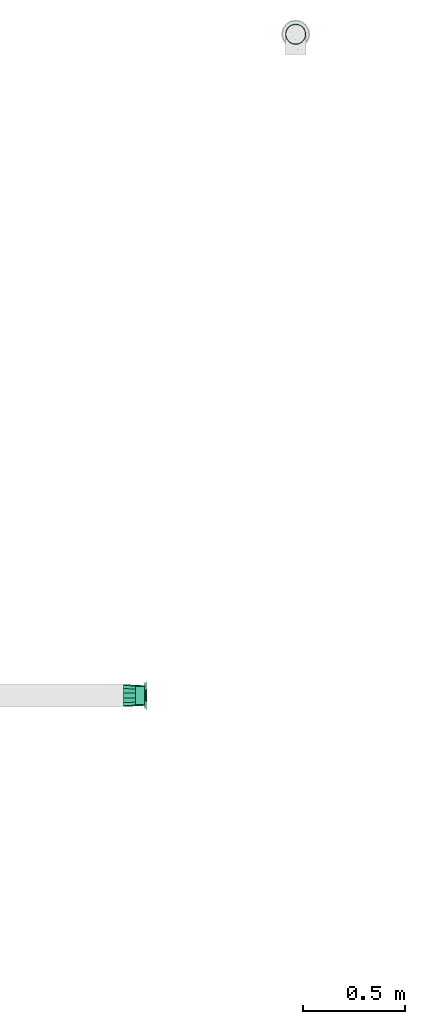
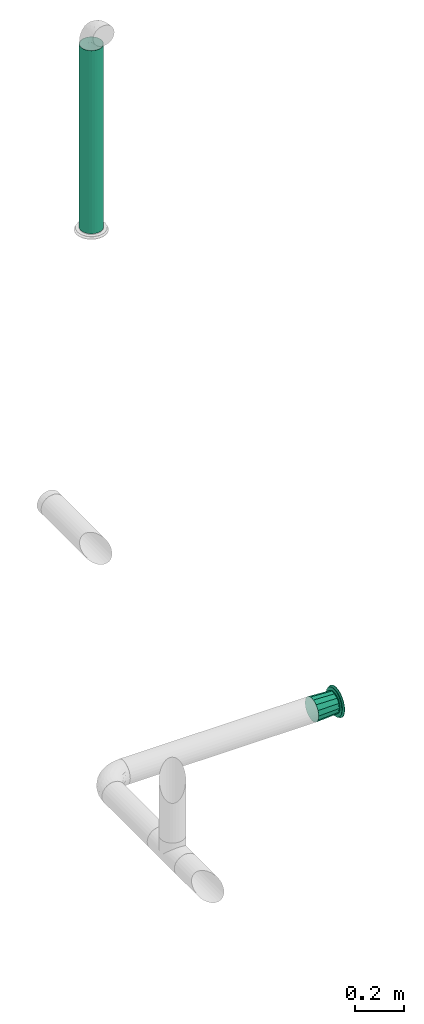
# One storey, part 99 of 103: 1 flow fitting, 1 flow segment, 1 flow terminal.
"""IFC2X3 building model written with IfcOpenShell, lengths in millimetres."""

from ifc_helpers import new_model, entity, si_unit, converted_unit, derived_unit, direction, frame, origin_with_axes, origin_2d_with_axis, place, context, subcontext, project, spatial, hollow_circle, extrude, open_shell, surface_model, source, transform, mapped, material, layer, layer_set, layer_usage, type_object, element, save


model = new_model("IFC2X3")

# Units and contexts
model_context = context("Model", 3, precision=1e-05, world=origin_with_axes(), true_north=direction((0.0, 1.0)))
body_context = subcontext(model_context, "Body", "Model", "MODEL_VIEW")
ifc_project = project(units=[si_unit("AREAUNIT", "SQUARE_METRE"), si_unit("VOLUMEUNIT", "CUBIC_METRE", prefix="DECI"), si_unit("TIMEUNIT", "SECOND"), si_unit("THERMODYNAMICTEMPERATUREUNIT", "DEGREE_CELSIUS"), si_unit("PRESSUREUNIT", "PASCAL"), si_unit("MASSUNIT", "GRAM", prefix="KILO"), si_unit("LENGTHUNIT", "METRE", prefix="MILLI"), si_unit("POWERUNIT", "WATT"), si_unit("ELECTRICCURRENTUNIT", "AMPERE"), si_unit("ELECTRICVOLTAGEUNIT", "VOLT"), derived_unit("VOLUMETRICFLOWRATEUNIT", [(si_unit("VOLUMEUNIT", "CUBIC_METRE", prefix="DECI"), 1), (si_unit("TIMEUNIT", "SECOND"), -1)]), derived_unit("LINEARVELOCITYUNIT", [(si_unit("LENGTHUNIT", "METRE"), 1), (si_unit("TIMEUNIT", "SECOND"), -1)]), derived_unit("MASSDENSITYUNIT", [(si_unit("MASSUNIT", "GRAM", prefix="KILO"), 1), (si_unit("VOLUMEUNIT", "CUBIC_METRE"), -1)]), converted_unit("PLANEANGLEUNIT", "DEGREE", entity("IfcRatioMeasure", 0.01745), si_unit("PLANEANGLEUNIT", "RADIAN"), dimensions=[0, 0, 0, 0, 0, 0, 0])], contexts=[model_context])

# Site, building, storey
site_placement = place(None, origin_with_axes())
site = spatial("IfcSite", under=ifc_project, at=site_placement, CompositionType="ELEMENT")
building_placement = place(site_placement, origin_with_axes())
building = spatial("IfcBuilding", under=site, at=building_placement, Name="mc-building", CompositionType="ELEMENT")
storey_placement = place(building_placement, frame((0.0, 0.0, 5900.0), z_axis=(0.0, 0.0, 1.0), x_axis=(1.0, 0.0, 0.0)))
storey = spatial("IfcBuildingStorey", under=building, at=storey_placement, Name="3. Korrus", CompositionType="ELEMENT", Elevation=5900.0)

# Flow fitting
duct_fitting_type = type_object("IfcDuctFittingType", PredefinedType="TRANSITION")
shared_shape_1 = source(origin_with_axes(), body_context, "Body", "SurfaceModel", [
    surface_model("IfcShellBasedSurfaceModel", [(0.0, 12.94095, 48.29629), (0.0, -35.35534, 35.35534), (0.0, 0.0, 50.0), (0.0, 35.35534, 35.35534), (0.0, 25.0, 43.30127), (0.0, 43.30127, 25.0), (0.0, 48.29629, 12.94095), (0.0, -12.94095, 48.29629), (0.0, -25.0, 43.30127), (0.0, -48.29629, 12.94095), (0.0, -43.30127, 25.0), (0.0, -25.0, -43.30127), (0.0, -48.29629, -12.94095), (0.0, -50.0, 0.0), (0.0, 48.29629, -12.94095), (0.0, 12.94095, -48.29629), (0.0, 43.30127, -25.0), (0.0, 35.35534, -35.35534), (0.0, 25.0, -43.30127), (0.0, -35.35534, -35.35534), (0.0, -43.30127, -25.0), (0.0, -12.94095, -48.29629), (0.0, 0.0, -50.0), (0.0, 50.0, 0.0), (100.0, -55.0, 0.0), (100.0, -12.23865, 53.62104), (100.0, -34.29194, 43.00073), (100.0, 49.55329, -23.86361), (100.0, 12.23865, 53.62104), (100.0, 34.29194, 43.00073), (100.0, 55.0, 0.0), (100.0, 49.55329, 23.86361), (100.0, -49.55329, 23.86361), (100.0, 12.23865, -53.62104), (100.0, -49.55329, -23.86361), (100.0, -34.29194, -43.00073), (100.0, 34.29194, -43.00073), (100.0, -12.23865, -53.62104), (0.0, 11.12605, 48.7464), (0.0, -11.12605, 48.7464), (0.0, 31.17449, 39.09157), (0.0, -45.04844, -21.69419), (0.0, -45.04844, 21.69419), (0.0, -31.17449, 39.09157), (0.0, 45.04844, 21.69419), (0.0, 45.04844, -21.69419), (0.0, 31.17449, -39.09157), (0.0, -31.17449, -39.09157), (0.0, -11.12605, -48.7464), (0.0, 11.12605, -48.7464), (0.0, -47.52422, -10.84709), (100.0, -41.92261, -33.43217), (0.0, -38.11147, -30.39288), (100.0, 41.92261, -33.43217), (0.0, 38.11147, -30.39288), (0.0, -21.15027, -43.91899), (100.0, -23.2653, -48.31088), (100.0, -52.32388, -11.72483), (100.0, 0.0, -53.62104), (0.0, 0.0, -48.7464), (100.0, 23.2653, -48.31088), (0.0, 21.15027, -43.91899), (100.0, 52.32388, -11.72483), (0.0, 47.52422, -10.84709), (0.0, 47.52422, 10.84709), (100.0, 41.92261, 33.43217), (0.0, 38.11147, 30.39288), (100.0, -41.92261, 33.43217), (0.0, -38.11147, 30.39288), (0.0, 21.15027, 43.91899), (100.0, 23.2653, 48.31088), (100.0, 52.32388, 11.72483), (100.0, 0.0, 53.62104), (0.0, 0.0, 48.7464), (100.0, -23.2653, 48.31088), (0.0, -21.15027, 43.91899), (100.0, -52.32388, 11.72483), (0.0, -47.52422, 10.84709), (100.0, 27.5, -47.63139), (100.0, 0.0, -55.0), (100.0, 14.23505, -53.12592), (100.0, 38.89087, -38.89087), (100.0, -27.5, -47.63139), (100.0, 47.63139, -27.5), (100.0, 53.12592, -14.23505), (100.0, -14.23505, -53.12592), (100.0, -47.63139, -27.5), (100.0, -38.89087, -38.89087), (100.0, -53.12592, -14.23505), (100.0, 53.12592, 14.23505), (100.0, 47.63139, 27.5), (100.0, 27.5, 47.63139), (100.0, 38.89087, 38.89087), (100.0, 14.23505, 53.12592), (100.0, 0.0, 55.0), (100.0, -47.63139, 27.5), (100.0, -53.12592, 14.23505), (100.0, -27.5, 47.63139), (100.0, -38.89087, 38.89087), (100.0, -14.23505, 53.12592), (98.0, 0.0, 55.0), (98.0, 14.23505, 53.12592), (98.0, 27.5, 47.63139), (98.0, 38.89087, 38.89087), (98.0, 47.63139, 27.5), (98.0, -47.63139, 27.5), (98.0, 53.12592, -14.23505), (98.0, -27.5, 47.63139), (98.0, -14.23505, 53.12592), (98.0, -38.89087, 38.89087), (98.0, -55.0, 0.0), (98.0, -53.12592, 14.23505), (98.0, 53.12592, 14.23505), (98.0, 47.63139, -27.5), (98.0, -27.5, -47.63139), (98.0, 0.0, -55.0), (98.0, 38.89087, -38.89087), (98.0, 27.5, -47.63139), (98.0, 14.23505, -53.12592), (98.0, -47.63139, -27.5), (98.0, -38.89087, -38.89087), (98.0, -53.12592, -14.23505), (98.0, -14.23505, -53.12592), (98.0, 55.0, 0.0), (2.0, 12.94095, -48.29629), (2.0, 25.0, -43.30127), (2.0, 35.35534, -35.35534), (2.0, 43.30127, -25.0), (2.0, 48.29629, -12.94095), (2.0, 0.0, -50.0), (2.0, 50.0, 0.0), (2.0, -25.0, -43.30127), (2.0, -12.94095, -48.29629), (2.0, -35.35534, -35.35534), (2.0, -48.29629, -12.94095), (2.0, -43.30127, -25.0), (2.0, -48.29629, 12.94095), (2.0, 48.29629, 12.94095), (2.0, 43.30127, 25.0), (2.0, 35.35534, 35.35534), (2.0, -35.35534, 35.35534), (2.0, 12.94095, 48.29629), (2.0, 25.0, 43.30127), (2.0, 0.0, 50.0), (2.0, -43.30127, 25.0), (2.0, -50.0, 0.0), (2.0, -12.94095, 48.29629), (2.0, -25.0, 43.30127)], [open_shell([[[0, 1, 2]], [[3, 0, 4]], [[3, 5, 6]], [[0, 3, 1]], [[6, 1, 3]], [[7, 1, 8]], [[7, 2, 1]], [[1, 9, 10]], [[9, 1, 11]], [[12, 13, 9]], [[11, 1, 6]], [[6, 14, 11]], [[15, 14, 16]], [[17, 18, 15]], [[17, 15, 16]], [[11, 14, 15]], [[12, 19, 20]], [[19, 12, 11]], [[15, 21, 11]], [[12, 9, 11]], [[22, 21, 15]], [[14, 6, 23]], [[24, 25, 26]], [[25, 27, 28]], [[29, 28, 27]], [[27, 30, 31]], [[31, 29, 27]], [[24, 26, 32]], [[33, 24, 34]], [[33, 34, 35]], [[36, 27, 33]], [[33, 27, 24]], [[35, 37, 33]], [[24, 27, 25]], [[38, 23, 39]], [[40, 23, 38]], [[41, 42, 43]], [[41, 13, 42]], [[23, 43, 39]], [[40, 44, 23]], [[41, 23, 45]], [[41, 45, 46]], [[47, 41, 48]], [[49, 48, 41]], [[41, 46, 49]], [[23, 41, 43]], [[34, 50, 41]], [[47, 51, 52]], [[45, 27, 53]], [[36, 54, 53]], [[55, 48, 56]], [[34, 57, 50]], [[57, 13, 50]], [[13, 57, 24]], [[55, 35, 47]], [[35, 51, 47]], [[51, 41, 52]], [[58, 59, 49]], [[60, 61, 46]], [[37, 59, 58]], [[62, 63, 23]], [[35, 55, 56]], [[23, 30, 62]], [[53, 54, 45]], [[48, 37, 56]], [[33, 49, 61]], [[49, 33, 58]], [[54, 36, 46]], [[63, 27, 45]], [[34, 41, 51]], [[33, 61, 60]], [[48, 59, 37]], [[27, 63, 62]], [[46, 36, 60]], [[31, 64, 44]], [[40, 65, 66]], [[42, 32, 67]], [[26, 68, 67]], [[69, 38, 70]], [[31, 71, 64]], [[71, 23, 64]], [[23, 71, 30]], [[69, 29, 40]], [[29, 65, 40]], [[65, 44, 66]], [[72, 73, 39]], [[74, 75, 43]], [[28, 73, 72]], [[76, 77, 13]], [[29, 69, 70]], [[13, 24, 76]], [[67, 68, 42]], [[38, 28, 70]], [[25, 39, 75]], [[39, 25, 72]], [[68, 26, 43]], [[77, 32, 42]], [[31, 44, 65]], [[25, 75, 74]], [[38, 73, 28]], [[32, 77, 76]], [[43, 26, 74]], [[78, 79, 80]], [[81, 82, 78]], [[82, 83, 84]], [[81, 83, 82]], [[30, 82, 84]], [[79, 82, 85]], [[79, 78, 82]], [[82, 86, 87]], [[82, 30, 86]], [[24, 88, 86]], [[86, 30, 89]], [[90, 24, 89]], [[91, 90, 92]], [[91, 93, 94]], [[90, 91, 24]], [[94, 95, 91]], [[24, 95, 96]], [[24, 91, 95]], [[94, 97, 98]], [[98, 95, 94]], [[97, 94, 99]], [[89, 24, 86]], [[100, 101, 102]], [[100, 102, 103]], [[100, 104, 105]], [[104, 100, 103]], [[106, 105, 104]], [[100, 107, 108]], [[100, 109, 107]], [[105, 110, 111]], [[109, 100, 105]], [[105, 106, 110]], [[106, 104, 112]], [[106, 113, 110]], [[113, 114, 110]], [[115, 116, 117]], [[113, 116, 115]], [[117, 118, 115]], [[119, 114, 120]], [[121, 110, 119]], [[114, 115, 122]], [[119, 110, 114]], [[115, 114, 113]], [[123, 106, 112]], [[121, 88, 110]], [[119, 86, 121]], [[82, 120, 114]], [[119, 120, 87]], [[85, 114, 122]], [[121, 86, 88]], [[88, 24, 110]], [[85, 82, 114]], [[87, 120, 82]], [[87, 86, 119]], [[79, 85, 122]], [[122, 115, 79]], [[118, 80, 115]], [[117, 78, 118]], [[83, 116, 113]], [[117, 116, 81]], [[84, 113, 106]], [[117, 81, 78]], [[78, 80, 118]], [[30, 84, 106]], [[83, 113, 84]], [[83, 81, 116]], [[123, 30, 106]], [[115, 80, 79]], [[112, 89, 123]], [[104, 90, 112]], [[91, 103, 102]], [[104, 103, 92]], [[93, 102, 101]], [[112, 90, 89]], [[89, 30, 123]], [[93, 91, 102]], [[92, 103, 91]], [[92, 90, 104]], [[94, 93, 101]], [[101, 100, 94]], [[108, 99, 100]], [[107, 97, 108]], [[95, 109, 105]], [[107, 109, 98]], [[96, 105, 111]], [[107, 98, 97]], [[97, 99, 108]], [[24, 96, 111]], [[95, 105, 96]], [[95, 98, 109]], [[110, 24, 111]], [[100, 99, 94]], [[124, 125, 126]], [[124, 126, 127]], [[124, 128, 129]], [[128, 124, 127]], [[129, 128, 130]], [[129, 131, 132]], [[129, 130, 131]], [[133, 134, 135]], [[134, 133, 131]], [[131, 136, 134]], [[131, 130, 137]], [[137, 138, 139]], [[140, 137, 139]], [[140, 139, 141]], [[141, 139, 142]], [[140, 141, 143]], [[136, 140, 144]], [[145, 134, 136]], [[140, 146, 147]], [[131, 140, 136]], [[143, 146, 140]], [[131, 137, 140]], [[12, 134, 13]], [[20, 135, 12]], [[131, 19, 11]], [[20, 19, 133]], [[132, 11, 21]], [[12, 135, 134]], [[134, 145, 13]], [[132, 131, 11]], [[133, 19, 131]], [[133, 135, 20]], [[129, 132, 21]], [[21, 22, 129]], [[15, 124, 22]], [[18, 125, 15]], [[127, 17, 16]], [[18, 17, 126]], [[128, 16, 14]], [[18, 126, 125]], [[125, 124, 15]], [[130, 128, 14]], [[127, 16, 128]], [[127, 126, 17]], [[23, 130, 14]], [[22, 124, 129]], [[6, 137, 23]], [[5, 138, 6]], [[142, 3, 4]], [[5, 3, 139]], [[141, 4, 0]], [[6, 138, 137]], [[137, 130, 23]], [[141, 142, 4]], [[139, 3, 142]], [[139, 138, 5]], [[143, 141, 0]], [[0, 2, 143]], [[7, 146, 2]], [[8, 147, 7]], [[144, 1, 10]], [[8, 1, 140]], [[136, 10, 9]], [[8, 140, 147]], [[147, 146, 7]], [[145, 136, 9]], [[144, 10, 136]], [[144, 140, 1]], [[13, 145, 9]], [[2, 146, 143]]])]),
])
flow_fitting_placement = place(storey_placement, frame((35206.81103, 9477.62755, 2345.0), z_axis=(0.0, 0.0, 1.0), x_axis=(-1.0, 0.0, 0.0)))
element("IfcFlowFitting", 1, at=flow_fitting_placement, inside=storey, type_object=duct_fitting_type, context=body_context, shape_type="MappedRepresentation", body=[
    mapped(shared_shape_1, transform((0.0, 0.0, 0.0), scale=1.0)),
])

# Flow segment
ifc_material = material(Name="FZ1")
ifc_layer = layer(ifc_material, 0.0)
ifc_layer_set = layer_set([ifc_layer], Name="FZ1")
ifc_layer_usage = layer_usage(ifc_layer_set, "AXIS1", "POSITIVE", 0.0)
duct_segment_type = type_object("IfcDuctSegmentType", PredefinedType="RIGIDSEGMENT")
shared_shape_2 = source(origin_with_axes(), body_context, "Body", "SweptSolid", [
    extrude(hollow_circle(Radius=50.0, WallThickness=2.0, at=origin_2d_with_axis()), frame((0.0, 0.0, 0.0), z_axis=(1.0, 0.0, 0.0), x_axis=(0.0, 1.0, 0.0)), (0.0, 0.0, 1.0), 906.0),
])
flow_segment_placement = place(storey_placement, frame((35954.21103, 12733.41275, 2461.97044), z_axis=(1.0, 0.0, 0.0), x_axis=(0.0, 0.0, 1.0)))
element("IfcFlowSegment", 2, at=flow_segment_placement, inside=storey, type_object=duct_segment_type, material=ifc_layer_usage, context=body_context, shape_type="MappedRepresentation", body=[
    mapped(shared_shape_2, transform((0.0, 0.0, 0.0), scale=1.0)),
])

# Flow terminal
air_terminal_type = type_object("IfcAirTerminalType", Name="100", PredefinedType="NOTDEFINED")
shared_shape_3 = source(origin_with_axes(), body_context, "Body", "SurfaceModel", [
    surface_model("IfcShellBasedSurfaceModel", [(11.2, -70.0, 0.0), (11.2, -67.61481, -18.11733), (11.2, -67.61481, 18.11733), (6.2, -14.64625, -20.15883), (9.2, -22.36867, -22.36867), (6.2, -21.19625, -15.39997), (9.2, 16.375, -28.36233), (6.2, 8.09625, -24.91768), (6.2, 14.64625, -20.15883), (6.2, -8.09625, -24.91768), (9.2, -16.375, -28.36233), (6.2, 21.19625, -15.39997), (9.2, 22.36867, -22.36867), (9.2, -8.1875, -30.55617), (9.2, 8.1875, -30.55617), (9.2, 28.36233, -16.375), (9.2, -28.36233, -16.375), (6.2, 14.64625, 20.15883), (9.2, 22.36867, 22.36867), (6.2, 21.19625, 15.39997), (9.2, -16.375, 28.36233), (6.2, -8.09625, 24.91768), (6.2, -14.64625, 20.15883), (6.2, 8.09625, 24.91768), (9.2, 16.375, 28.36233), (6.2, -21.19625, 15.39997), (9.2, -22.36867, 22.36867), (9.2, 8.1875, 30.55617), (9.2, -8.1875, 30.55617), (9.2, -28.36233, 16.375), (9.2, 28.36233, 16.375), (6.2, -53.11211, -25.57744), (6.2, -36.75472, -46.08897), (6.2, -13.11761, -57.472), (6.2, 13.11761, -57.472), (6.2, 36.75472, -46.08897), (6.2, 53.11211, -25.57744), (0.0, -12.53288, -63.00706), (6.2, 0.0, -57.472), (0.0, -46.3155, -46.3155), (0.0, -35.69063, -53.4148), (0.0, 0.0, -65.5), (6.2, 44.93342, -35.83321), (0.0, 46.3155, -46.3155), (0.0, 35.69063, -53.4148), (6.2, -44.93342, -35.83321), (0.0, 12.53288, -63.00706), (0.0, 25.06576, -60.51411), (6.2, 56.03105, -12.78872), (0.0, 60.51411, -25.06576), (0.0, 63.00706, -12.53288), (0.0, 53.4148, -35.69063), (0.0, -25.06576, -60.51411), (0.0, -63.00706, -12.53288), (0.0, -60.51411, -25.06576), (6.2, -56.03105, -12.78872), (0.0, -53.4148, -35.69063), (6.2, 13.11761, 57.472), (0.0, 12.53288, 63.00706), (6.2, 0.0, 57.472), (6.2, 36.75472, 46.08897), (0.0, 46.3155, 46.3155), (0.0, 35.69063, 53.4148), (0.0, 0.0, 65.5), (6.2, -44.93342, 35.83321), (6.2, -36.75472, 46.08897), (0.0, -46.3155, 46.3155), (0.0, -35.69063, 53.4148), (6.2, 44.93342, 35.83321), (0.0, -12.53288, 63.00706), (0.0, -25.06576, 60.51411), (6.2, -13.11761, 57.472), (6.2, -56.03105, 12.78872), (0.0, -60.51411, 25.06576), (0.0, -63.00706, 12.53288), (0.0, -53.4148, 35.69063), (0.0, 25.06576, 60.51411), (0.0, 63.00706, 12.53288), (0.0, 60.51411, 25.06576), (6.2, 56.03105, 12.78872), (0.0, 53.4148, 35.69063), (-3.1, 43.30127, 25.0), (-3.1, -48.29629, -12.94095), (-3.1, -43.30127, 25.0), (-3.1, 25.0, -43.30127), (-3.1, 48.29629, -12.94095), (-3.1, 35.35534, -35.35534), (-3.1, -35.35534, -35.35534), (-3.1, -25.0, -43.30127), (-43.1, 43.46666, 11.64686), (-3.1, 38.97115, 22.5), (-3.1, 43.46666, 11.64686), (-3.1, 45.0, 0.0), (-43.1, 45.0, 0.0), (-3.1, 31.81981, 31.81981), (-43.1, 38.97115, 22.5), (-43.1, -38.97115, 22.5), (-3.1, -38.97115, 22.5), (-3.1, -31.81981, 31.81981), (-3.1, -43.46666, 11.64686), (-43.1, -43.46666, 11.64686), (-43.1, -45.0, 0.0), (-3.1, -45.0, 0.0), (-43.1, -43.46666, -11.64686), (-3.1, -38.97115, -22.5), (-3.1, -43.46666, -11.64686), (-3.1, -11.64686, -43.46666), (-3.1, -22.5, -38.97115), (-43.1, -22.5, -38.97115), (-3.1, -31.81981, -31.81981), (-43.1, -38.97115, -22.5), (-43.1, 22.5, -38.97115), (-3.1, 22.5, -38.97115), (-3.1, 11.64686, -43.46666), (-43.1, 38.97115, -22.5), (-3.1, 38.97115, -22.5), (-3.1, 31.81981, -31.81981), (-3.1, 43.46666, -11.64686), (-43.1, 43.46666, -11.64686), (11.2, -49.49747, -49.49747), (11.2, -35.0, -60.62178), (11.2, -18.11733, -67.61481), (11.2, 67.61481, 18.11733), (11.2, -60.62178, -35.0), (11.2, 18.11733, -67.61481), (11.2, 35.0, -60.62178), (11.2, 0.0, -70.0), (11.2, 60.62178, -35.0), (11.2, 67.61481, -18.11733), (11.2, 49.49747, -49.49747), (11.2, -49.49747, 49.49747), (11.2, -60.62178, 35.0), (11.2, -35.0, 60.62178), (11.2, -18.11733, 67.61481), (11.2, 0.0, 70.0), (11.2, 60.62178, 35.0), (11.2, 49.49747, 49.49747), (11.2, 70.0, 0.0), (11.2, 35.0, 60.62178), (11.2, 18.11733, 67.61481), (9.2, -49.49747, 49.49747), (9.2, -35.0, 60.62178), (9.2, -18.11733, 67.61481), (9.2, -67.61481, 18.11733), (9.2, -70.0, 0.0), (9.2, -60.62178, 35.0), (9.2, 67.61481, 18.11733), (9.2, 35.0, 60.62178), (9.2, 18.11733, 67.61481), (9.2, 0.0, 70.0), (9.2, 60.62178, 35.0), (9.2, 49.49747, 49.49747), (9.2, -67.61481, -18.11733), (9.2, -49.49747, -49.49747), (9.2, -60.62178, -35.0), (9.2, -18.11733, -67.61481), (9.2, 70.0, 0.0), (9.2, -35.0, -60.62178), (9.2, 0.0, -70.0), (9.2, 60.62178, -35.0), (9.2, 49.49747, -49.49747), (9.2, 67.61481, -18.11733), (9.2, 35.0, -60.62178), (9.2, 18.11733, -67.61481), (9.2, -32.75, 0.0), (9.2, 0.0, 32.75), (9.2, 32.75, 0.0), (9.2, 0.0, -32.75), (6.2, 26.2, 0.0), (6.2, -26.2, 0.0), (9.2, -31.06579, -6.28555), (6.2, -23.69812, -7.69999), (6.2, 23.69812, -7.69999), (9.2, 31.06579, -6.28555), (6.2, 0.0, -24.91768), (9.2, 31.06579, 6.28555), (6.2, 23.69812, 7.69999), (6.2, -23.69812, 7.69999), (9.2, -31.06579, 6.28555), (6.2, 0.0, 24.91768), (6.2, 53.11211, 25.57744), (6.2, 58.95, 0.0), (6.2, -53.11211, 25.57744), (6.2, -58.95, 0.0), (0.0, 65.5, 0.0), (0.0, -65.5, 0.0), (6.2, -24.93616, -51.78048), (6.2, 24.93616, -51.78048), (6.2, 24.93616, 51.78048), (6.2, -24.93616, 51.78048), (-3.1, 0.0, 50.0), (-3.1, 35.35534, 35.35534), (-3.1, -12.94095, 48.29629), (-3.1, -25.0, 43.30127), (-3.1, -35.35534, 35.35534), (-3.1, 25.0, 43.30127), (-3.1, 12.94095, 48.29629), (-3.1, 48.29629, 12.94095), (-3.1, 50.0, 0.0), (-3.1, -50.0, 0.0), (-3.1, -48.29629, 12.94095), (-3.1, -43.30127, -25.0), (-3.1, -12.94095, -48.29629), (-3.1, 0.0, -50.0), (-3.1, 43.30127, -25.0), (-3.1, 12.94095, -48.29629), (0.0, -12.94095, -48.29629), (0.0, 0.0, -50.0), (0.0, -25.0, -43.30127), (0.0, -35.35534, -35.35534), (0.0, -48.29629, -12.94095), (0.0, 25.0, -43.30127), (0.0, -43.30127, -25.0), (0.0, 43.30127, 25.0), (0.0, 12.94095, -48.29629), (0.0, 43.30127, -25.0), (0.0, 48.29629, -12.94095), (0.0, 35.35534, -35.35534), (0.0, 50.0, 0.0), (0.0, -50.0, 0.0), (0.0, -48.29629, 12.94095), (0.0, -43.30127, 25.0), (0.0, -35.35534, 35.35534), (0.0, -12.94095, 48.29629), (0.0, -25.0, 43.30127), (0.0, 35.35534, 35.35534), (0.0, 0.0, 50.0), (0.0, 48.29629, 12.94095), (0.0, 25.0, 43.30127), (0.0, 12.94095, 48.29629), (-43.1, -22.5, 38.97115), (-43.1, -11.64686, 43.46666), (-43.1, 0.0, 45.0), (-43.1, 11.64686, 43.46666), (-43.1, -31.81981, 31.81981), (-43.1, 31.81981, 31.81981), (-43.1, 22.5, 38.97115), (-43.1, -31.81981, -31.81981), (-43.1, 31.81981, -31.81981), (-43.1, -11.64686, -43.46666), (-43.1, 11.64686, -43.46666), (-43.1, 0.0, -45.0), (-3.1, 0.0, -45.0), (-3.1, 0.0, 45.0), (-3.1, -22.5, 38.97115), (-3.1, -11.64686, 43.46666), (-3.1, 11.64686, 43.46666), (-3.1, 22.5, 38.97115)], [open_shell([[[0, 1, 2]], [[3, 4, 5]], [[6, 7, 8]], [[3, 9, 10]], [[4, 3, 10]], [[11, 12, 8]], [[13, 10, 9]], [[7, 6, 14]], [[6, 8, 12]], [[12, 11, 15]], [[16, 5, 4]], [[17, 18, 19]], [[20, 21, 22]], [[17, 23, 24]], [[18, 17, 24]], [[25, 26, 22]], [[27, 24, 23]], [[21, 20, 28]], [[20, 22, 26]], [[26, 25, 29]], [[30, 19, 18]], [[31, 32, 33]], [[34, 35, 36]], [[33, 37, 38]], [[32, 39, 40]], [[41, 38, 37]], [[42, 35, 43]], [[44, 43, 35]], [[39, 32, 45]], [[46, 47, 34]], [[48, 49, 50]], [[38, 46, 34]], [[42, 43, 51]], [[33, 52, 37]], [[53, 54, 55]], [[46, 38, 41]], [[56, 39, 45]], [[57, 58, 59]], [[60, 61, 62]], [[63, 59, 58]], [[64, 65, 66]], [[67, 66, 65]], [[61, 60, 68]], [[69, 70, 71]], [[72, 73, 74]], [[59, 69, 71]], [[64, 66, 75]], [[57, 76, 58]], [[77, 78, 79]], [[69, 59, 63]], [[80, 61, 68]], [[81, 82, 83]], [[84, 85, 86]], [[87, 82, 88]], [[89, 90, 91]], [[91, 92, 93]], [[94, 90, 95]], [[96, 97, 98]], [[99, 97, 100]], [[101, 102, 99]], [[103, 104, 105]], [[105, 102, 101]], [[106, 107, 108]], [[109, 104, 110]], [[111, 112, 113]], [[114, 115, 116]], [[117, 115, 118]], [[93, 92, 117]], [[119, 120, 121]], [[1, 119, 121]], [[122, 1, 121]], [[123, 119, 1]], [[124, 122, 121]], [[125, 122, 124]], [[121, 126, 124]], [[127, 128, 129]], [[129, 128, 122]], [[129, 122, 125]], [[130, 131, 2]], [[132, 130, 2]], [[122, 133, 2]], [[132, 2, 133]], [[134, 133, 122]], [[135, 136, 122]], [[122, 128, 137]], [[136, 138, 122]], [[139, 122, 138]], [[122, 139, 134]], [[2, 1, 122]], [[140, 141, 142]], [[143, 140, 142]], [[142, 144, 143]], [[145, 140, 143]], [[146, 144, 142]], [[147, 146, 148]], [[149, 148, 146]], [[150, 146, 151]], [[147, 151, 146]], [[146, 142, 149]], [[146, 152, 144]], [[153, 154, 152]], [[155, 153, 152]], [[146, 156, 155]], [[157, 153, 155]], [[158, 155, 156]], [[159, 160, 161]], [[156, 161, 160]], [[160, 162, 156]], [[163, 156, 162]], [[163, 158, 156]], [[152, 146, 155]], [[156, 128, 161]], [[161, 127, 159]], [[162, 160, 125]], [[129, 160, 159]], [[163, 162, 124]], [[128, 127, 161]], [[156, 137, 128]], [[162, 125, 124]], [[125, 160, 129]], [[159, 127, 129]], [[163, 124, 126]], [[126, 158, 163]], [[158, 121, 155]], [[155, 120, 157]], [[154, 153, 123]], [[119, 153, 157]], [[152, 154, 1]], [[120, 119, 157]], [[155, 121, 120]], [[152, 1, 0]], [[1, 154, 123]], [[153, 119, 123]], [[152, 0, 144]], [[126, 121, 158]], [[144, 2, 143]], [[143, 131, 145]], [[141, 140, 132]], [[130, 140, 145]], [[142, 141, 133]], [[2, 131, 143]], [[144, 0, 2]], [[141, 132, 133]], [[132, 140, 130]], [[145, 131, 130]], [[142, 133, 134]], [[134, 149, 142]], [[149, 139, 148]], [[148, 138, 147]], [[150, 151, 135]], [[136, 151, 147]], [[146, 150, 122]], [[138, 136, 147]], [[148, 139, 138]], [[146, 122, 137]], [[122, 150, 135]], [[151, 136, 135]], [[146, 137, 156]], [[134, 139, 149]], [[30, 24, 164]], [[24, 20, 164]], [[165, 20, 24]], [[164, 20, 29]], [[166, 30, 16]], [[16, 6, 166]], [[167, 6, 10]], [[30, 164, 16]], [[10, 6, 16]], [[6, 15, 166]], [[21, 19, 11]], [[23, 19, 21]], [[11, 19, 168]], [[7, 25, 21]], [[7, 5, 169]], [[21, 11, 7]], [[9, 5, 7]], [[169, 25, 7]], [[170, 164, 169]], [[170, 171, 16]], [[11, 172, 15]], [[172, 168, 173]], [[174, 13, 9]], [[166, 173, 168]], [[172, 173, 15]], [[169, 171, 170]], [[5, 16, 171]], [[167, 174, 14]], [[174, 167, 13]], [[14, 174, 7]], [[175, 166, 168]], [[175, 176, 30]], [[25, 177, 29]], [[177, 169, 178]], [[179, 27, 23]], [[164, 178, 169]], [[177, 178, 29]], [[168, 176, 175]], [[19, 30, 176]], [[165, 179, 28]], [[179, 165, 27]], [[28, 179, 21]], [[180, 60, 57]], [[181, 180, 65]], [[65, 57, 71]], [[180, 57, 65]], [[65, 182, 181]], [[182, 36, 181]], [[183, 34, 36]], [[31, 34, 183]], [[31, 33, 34]], [[182, 183, 36]], [[70, 63, 49]], [[70, 73, 66]], [[49, 63, 184]], [[78, 76, 61]], [[76, 78, 184]], [[184, 63, 76]], [[73, 70, 49]], [[39, 54, 185]], [[41, 39, 185]], [[52, 39, 41]], [[43, 185, 49]], [[185, 43, 47]], [[185, 47, 41]], [[73, 49, 185]], [[55, 54, 31]], [[31, 54, 56]], [[52, 186, 40]], [[53, 55, 183]], [[56, 45, 31]], [[185, 53, 183]], [[32, 40, 186]], [[33, 186, 52]], [[44, 35, 187]], [[49, 36, 51]], [[34, 47, 187]], [[42, 51, 36]], [[187, 47, 44]], [[49, 48, 36]], [[48, 50, 181]], [[184, 181, 50]], [[79, 78, 180]], [[180, 78, 80]], [[76, 188, 62]], [[77, 79, 181]], [[80, 68, 180]], [[184, 77, 181]], [[60, 62, 188]], [[57, 188, 76]], [[67, 65, 189]], [[73, 182, 75]], [[71, 70, 189]], [[64, 75, 182]], [[189, 70, 67]], [[73, 72, 182]], [[72, 74, 183]], [[185, 183, 74]], [[190, 191, 192]], [[193, 192, 194]], [[83, 192, 81]], [[194, 192, 83]], [[195, 191, 196]], [[191, 190, 196]], [[197, 198, 81]], [[81, 192, 191]], [[198, 84, 81]], [[199, 200, 83]], [[81, 88, 82]], [[201, 82, 87]], [[88, 81, 202]], [[81, 203, 202]], [[204, 86, 85]], [[205, 203, 84]], [[84, 198, 85]], [[81, 84, 203]], [[199, 83, 82]], [[206, 207, 208]], [[209, 208, 210]], [[210, 208, 211]], [[212, 209, 210]], [[210, 211, 213]], [[214, 211, 207]], [[211, 208, 207]], [[215, 216, 217]], [[211, 217, 216]], [[216, 218, 211]], [[219, 210, 220]], [[221, 210, 213]], [[222, 221, 223]], [[213, 223, 221]], [[224, 222, 223]], [[223, 225, 226]], [[227, 213, 218]], [[218, 213, 211]], [[228, 229, 225]], [[223, 213, 225]], [[226, 225, 229]], [[221, 220, 210]], [[199, 220, 200]], [[200, 221, 83]], [[193, 194, 224]], [[222, 194, 83]], [[192, 193, 223]], [[220, 221, 200]], [[199, 219, 220]], [[193, 224, 223]], [[224, 194, 222]], [[83, 221, 222]], [[192, 223, 226]], [[226, 190, 192]], [[190, 229, 196]], [[196, 228, 195]], [[81, 191, 213]], [[225, 191, 195]], [[197, 81, 227]], [[228, 225, 195]], [[196, 229, 228]], [[197, 227, 218]], [[227, 81, 213]], [[191, 225, 213]], [[197, 218, 198]], [[226, 229, 190]], [[198, 216, 85]], [[85, 215, 204]], [[84, 86, 211]], [[217, 86, 204]], [[205, 84, 214]], [[216, 215, 85]], [[198, 218, 216]], [[84, 211, 214]], [[211, 86, 217]], [[204, 215, 217]], [[205, 214, 207]], [[207, 203, 205]], [[203, 206, 202]], [[202, 208, 88]], [[201, 87, 212]], [[209, 87, 88]], [[82, 201, 210]], [[208, 209, 88]], [[202, 206, 208]], [[82, 210, 219]], [[210, 201, 212]], [[87, 209, 212]], [[82, 219, 199]], [[207, 206, 203]], [[230, 231, 232]], [[230, 232, 233]], [[230, 100, 96]], [[234, 230, 96]], [[100, 230, 233]], [[235, 89, 236]], [[100, 233, 236]], [[95, 89, 235]], [[118, 89, 93]], [[118, 236, 89]], [[118, 100, 236]], [[110, 103, 101]], [[237, 110, 101]], [[238, 108, 101]], [[237, 101, 108]], [[239, 108, 238]], [[114, 238, 118]], [[238, 101, 118]], [[240, 241, 111]], [[238, 111, 241]], [[238, 241, 239]], [[100, 118, 101]], [[106, 242, 107]], [[107, 112, 109]], [[102, 105, 104]], [[112, 104, 109]], [[92, 104, 117]], [[113, 112, 242]], [[112, 107, 242]], [[115, 117, 116]], [[112, 116, 117]], [[112, 117, 104]], [[92, 102, 104]], [[97, 99, 243]], [[98, 97, 244]], [[243, 245, 244]], [[97, 243, 244]], [[246, 243, 99]], [[90, 94, 91]], [[92, 91, 247]], [[94, 247, 91]], [[247, 99, 92]], [[247, 246, 99]], [[102, 92, 99]], [[101, 99, 100]], [[100, 97, 96]], [[230, 234, 244]], [[98, 234, 96]], [[231, 230, 245]], [[245, 230, 244]], [[244, 234, 98]], [[245, 243, 231]], [[243, 232, 231]], [[236, 233, 246]], [[236, 247, 235]], [[89, 95, 90]], [[94, 95, 235]], [[93, 89, 91]], [[232, 246, 233]], [[246, 247, 236]], [[243, 246, 232]], [[247, 94, 235]], [[93, 117, 118]], [[118, 115, 114]], [[111, 238, 112]], [[116, 238, 114]], [[240, 111, 113]], [[112, 238, 116]], [[240, 113, 242]], [[242, 241, 240]], [[108, 239, 106]], [[108, 107, 237]], [[103, 110, 104]], [[109, 110, 237]], [[101, 103, 105]], [[241, 106, 239]], [[242, 106, 241]], [[107, 109, 237]]])]),
])
flow_terminal_placement = place(storey_placement, frame((35209.91103, 9477.62755, 2345.0), z_axis=(0.0, 0.0, 1.0), x_axis=(1.0, 0.0, 0.0)))
element("IfcFlowTerminal", 3, at=flow_terminal_placement, inside=storey, type_object=air_terminal_type, Name="100", context=body_context, shape_type="MappedRepresentation", body=[
    mapped(shared_shape_3, transform((0.0, 0.0, 0.0), scale=1.0)),
])

save(model, "model.ifc")
